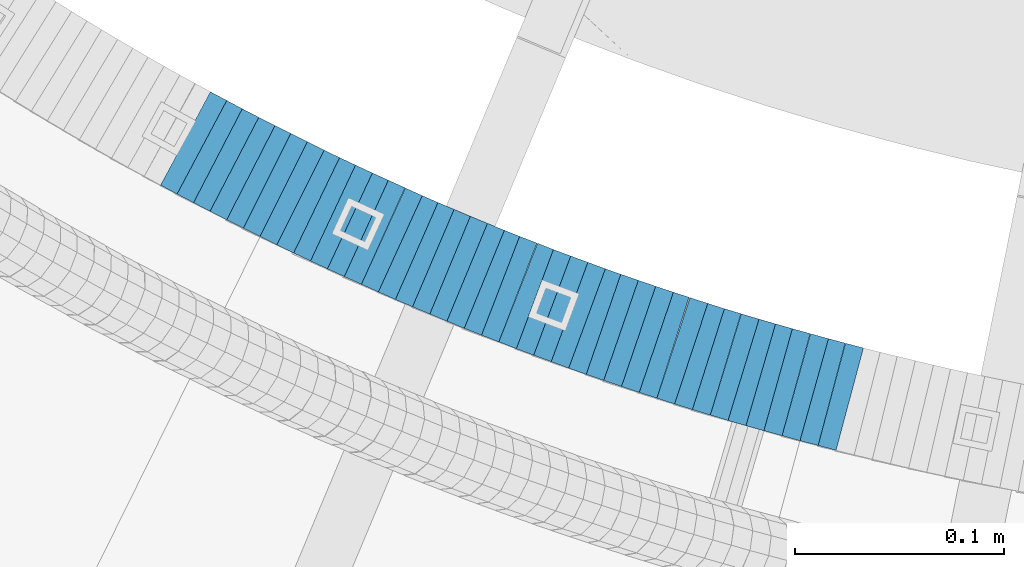
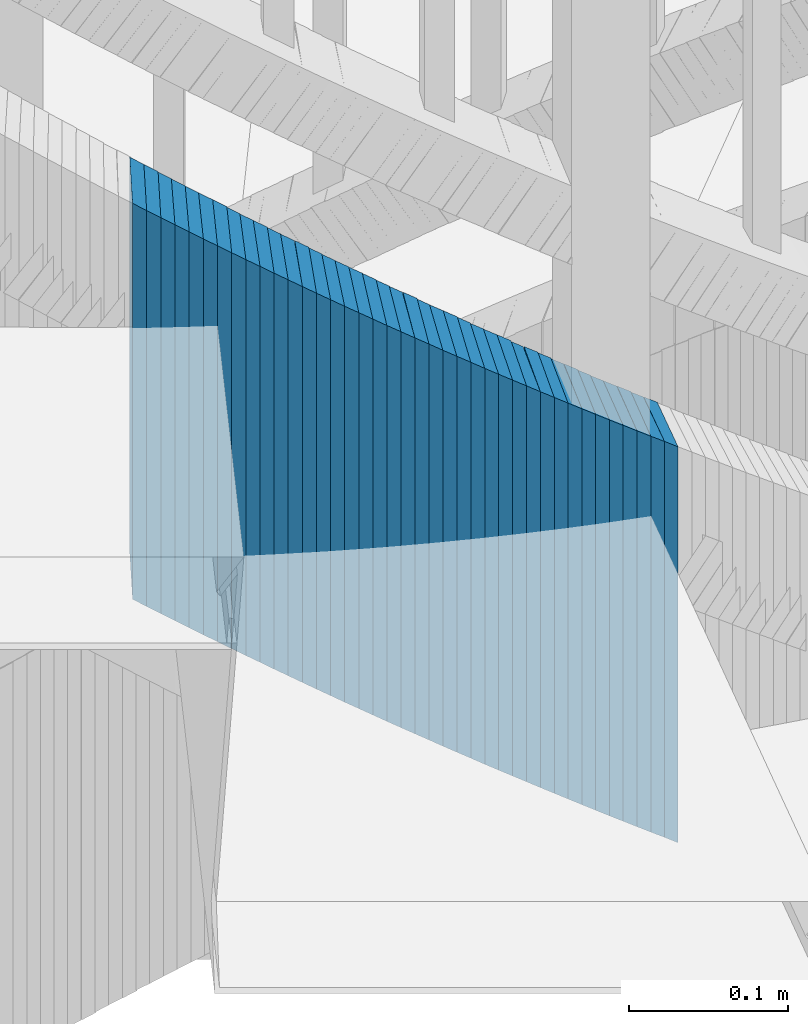
# One storey, part 879 of 975: 39 plates.
"""IFC2X3 building model written with IfcOpenShell, lengths in millimetres."""

from ifc_helpers import new_model, si_unit, frame, origin_with_axes, place, context, subcontext, project, spatial, faceted_brep, material, type_object, element, save


model = new_model("IFC2X3")

# Units and contexts
model_context = context("Model", 3, precision=1e-05, world=origin_with_axes())
body_context = subcontext(model_context, "Body", "Model", "MODEL_VIEW")
ifc_project = project(units=[si_unit("LENGTHUNIT", "METRE", prefix="MILLI"), si_unit("AREAUNIT", "SQUARE_METRE"), si_unit("VOLUMEUNIT", "CUBIC_METRE"), si_unit("MASSUNIT", "GRAM", prefix="KILO"), si_unit("TIMEUNIT", "SECOND"), si_unit("PLANEANGLEUNIT", "RADIAN"), si_unit("SOLIDANGLEUNIT", "STERADIAN"), si_unit("THERMODYNAMICTEMPERATUREUNIT", "DEGREE_CELSIUS"), si_unit("LUMINOUSINTENSITYUNIT", "LUMEN")], contexts=[model_context])

# Site, building, storey
site_placement = place(None, origin_with_axes())
site = spatial("IfcSite", under=ifc_project, at=site_placement, CompositionType="ELEMENT")
building_placement = place(site_placement, origin_with_axes())
building = spatial("IfcBuilding", under=site, at=building_placement, Name="Undefined", CompositionType="ELEMENT")
storey_placement = place(building_placement, origin_with_axes())
storey = spatial("IfcBuildingStorey", under=building, at=storey_placement, Name="Undefined", CompositionType="ELEMENT", Elevation=0.0)

# Plates
ifc_material = material(Name="STEEL/A36")
plate_type = type_object("IfcPlateType", PredefinedType="NOTDEFINED")
plate_1_placement = place(storey_placement, frame((34076.3886920628, 2171.20139217129, 3518.02500005032), z_axis=(-0.882970965859413, 0.469427601925255, 0.0), x_axis=(0.0, 0.0, 1.0)))
element("IfcPlate", 1, at=plate_1_placement, inside=storey, type_object=plate_type, material=ifc_material, Name="WALL", context=body_context, shape_type="Brep", body=[
    faceted_brep([(0.0, -25.3999999999724, -1.81898940354586e-11), (5.80000019073486, -25.3999999999942, 8.94930171964734), (5.80000019073486, 25.4000000000015, 8.94930171966917), (0.0, 25.3999999999869, 1.45519152283669e-11), (310.600006103516, -25.3999999999942, 8.94930171964734), (310.600006103516, 25.4000000000015, 8.94930171966917), (304.799987792969, -25.3999999999724, -1.81898940354586e-11), (304.799987792969, 25.3999999999869, 1.45519152283669e-11)], [[[0, 1, 2, 3]], [[1, 4, 5, 2]], [[4, 6, 7, 5]], [[6, 0, 3, 7]], [[5, 7, 3, 2]], [[6, 4, 1, 0]]]),
])
plate_2_placement = place(storey_placement, frame((34084.288692054, 2167.00139217108, 3512.32500005032), z_axis=(-0.882970965859413, 0.469427601925255, 0.0), x_axis=(0.0, 0.0, 1.0)))
element("IfcPlate", 2, at=plate_2_placement, inside=storey, type_object=plate_type, material=ifc_material, Name="WALL", context=body_context, shape_type="Brep", body=[
    faceted_brep([(0.0, -25.3999999999724, -1.81898940354586e-11), (5.69999980926514, -25.3999999999869, 8.94930171964734), (5.69999980926514, 25.4000000000051, 8.94930171966917), (0.0, 25.3999999999869, 1.45519152283669e-11), (310.5, -25.3999999999869, 8.94930171964734), (310.5, 25.4000000000051, 8.94930171966917), (304.799987792969, -25.3999999999724, -1.81898940354586e-11), (304.799987792969, 25.3999999999869, 1.45519152283669e-11)], [[[0, 1, 2, 3]], [[1, 4, 5, 2]], [[4, 6, 7, 5]], [[6, 0, 3, 7]], [[5, 7, 3, 2]], [[6, 4, 1, 0]]]),
])
plate_3_placement = place(storey_placement, frame((34091.9656160129, 2163.01857400308, 3506.52500005032), z_axis=(-0.887584423832732, 0.460645080913188, 0.0), x_axis=(0.0, 0.0, 1.0)))
element("IfcPlate", 3, at=plate_3_placement, inside=storey, type_object=plate_type, material=ifc_material, Name="WALL", context=body_context, shape_type="Brep", body=[
    faceted_brep([(0.0, -25.3999999999724, -1.81898940354586e-11), (5.80000019073486, -25.3999999999687, 8.90449333185097), (5.80000019073486, 25.3999999999833, 8.90449333192373), (0.0, 25.3999999999869, 1.45519152283669e-11), (310.600006103516, -25.3999999999687, 8.90449333185097), (310.600006103516, 25.3999999999833, 8.90449333192373), (304.799987792969, -25.3999999999724, -1.81898940354586e-11), (304.799987792969, 25.3999999999869, 1.45519152283669e-11)], [[[0, 1, 2, 3]], [[1, 4, 5, 2]], [[4, 6, 7, 5]], [[6, 0, 3, 7]], [[5, 7, 3, 2]], [[6, 4, 1, 0]]]),
])
plate_4_placement = place(storey_placement, frame((34099.8499370481, 2158.97823420287, 3500.82500005032), z_axis=(-0.889933250612687, 0.4560907908015, 0.0), x_axis=(0.0, 0.0, 1.0)))
element("IfcPlate", 4, at=plate_4_placement, inside=storey, type_object=plate_type, material=ifc_material, Name="WALL", context=body_context, shape_type="Brep", body=[
    faceted_brep([(0.0, -25.3999999999724, -1.81898940354586e-11), (5.69999980926514, -25.4000000000196, 8.98721313477654), (5.69999980926514, 25.4000000000669, 8.98721313470742), (0.0, 25.3999999999869, 1.45519152283669e-11), (310.5, -25.4000000000196, 8.98721313477654), (310.5, 25.4000000000669, 8.98721313470742), (304.799987792969, -25.3999999999724, -1.81898940354586e-11), (304.799987792969, 25.3999999999869, 1.45519152283669e-11)], [[[0, 1, 2, 3]], [[1, 4, 5, 2]], [[4, 6, 7, 5]], [[6, 0, 3, 7]], [[5, 7, 3, 2]], [[6, 4, 1, 0]]]),
])
plate_5_placement = place(storey_placement, frame((34107.6244562762, 2155.09238029339, 3495.02500005032), z_axis=(-0.894427191199916, 0.447213595099958, 0.0), x_axis=(0.0, 0.0, 1.0)))
element("IfcPlate", 5, at=plate_5_placement, inside=storey, type_object=plate_type, material=ifc_material, Name="WALL", context=body_context, shape_type="Brep", body=[
    faceted_brep([(0.0, -25.3999999999724, -1.81898940354586e-11), (5.80000019073486, -25.4000000000087, 8.9375610351708), (5.80000019073486, 25.400000000016, 8.93756103512715), (0.0, 25.3999999999869, 1.45519152283669e-11), (310.600006103516, -25.4000000000087, 8.9375610351708), (310.600006103516, 25.400000000016, 8.93756103512715), (304.799987792969, -25.3999999999724, -1.81898940354586e-11), (304.799987792969, 25.3999999999869, 1.45519152283669e-11)], [[[0, 1, 2, 3]], [[1, 4, 5, 2]], [[4, 6, 7, 5]], [[6, 0, 3, 7]], [[5, 7, 3, 2]], [[6, 4, 1, 0]]]),
])
for number, where, z_axis, x_axis, name in (
    (6, (34115.624456275, 2151.09238029301, 3489.32500005032), (-0.894427191199916, 0.447213595099958, 0.0), (0.0, 0.0, 1.0), "WALL"),
    (7, (34123.6244562739, 2147.09238029269, 3483.62500005032), (-0.894427191199916, 0.447213595099958, 0.0), (0.0, 0.0, 1.0), "WALL"),
):
    element("IfcPlate", number, at=place(storey_placement, frame(where, z_axis=z_axis, x_axis=x_axis)), inside=storey, type_object=plate_type, material=ifc_material, Name=name, context=body_context, shape_type="Brep", body=[
        faceted_brep([(0.0, -25.3999999999724, -1.81898940354586e-11), (5.69999980926514, -25.4000000000851, 8.94035816198448), (5.69999980926514, 25.4000000000524, 8.94035816188989), (0.0, 25.3999999999869, 1.45519152283669e-11), (310.5, -25.4000000000851, 8.94035816198448), (310.5, 25.4000000000524, 8.94035816188989), (304.799987792969, -25.3999999999724, -1.81898940354586e-11), (304.799987792969, 25.3999999999869, 1.45519152283669e-11)], [[[0, 1, 2, 3]], [[1, 4, 5, 2]], [[4, 6, 7, 5]], [[6, 0, 3, 7]], [[5, 7, 3, 2]], [[6, 4, 1, 0]]]),
    ])
plate_6_placement = place(storey_placement, frame((34131.3841476791, 2143.35937204668, 3477.82500005032), z_axis=(-0.901001669715669, 0.433815618863102, 0.0), x_axis=(0.0, 0.0, 1.0)))
element("IfcPlate", 8, at=plate_6_placement, inside=storey, type_object=plate_type, material=ifc_material, Name="WALL", context=body_context, shape_type="Brep", body=[
    faceted_brep([(0.0, -25.3999999999724, -1.81898940354586e-11), (5.80000019073486, -25.4000000000815, 8.99388694768095), (5.80000019073486, 25.4000000000342, 8.99388694761365), (0.0, 25.3999999999869, 1.45519152283669e-11), (310.600006103516, -25.4000000000815, 8.99388694768095), (310.600006103516, 25.4000000000342, 8.99388694761365), (304.799987792969, -25.3999999999724, -1.81898940354586e-11), (304.799987792969, 25.3999999999869, 1.45519152283669e-11)], [[[0, 1, 2, 3]], [[1, 4, 5, 2]], [[4, 6, 7, 5]], [[6, 0, 3, 7]], [[5, 7, 3, 2]], [[6, 4, 1, 0]]]),
])
plate_7_placement = place(storey_placement, frame((34139.2531243221, 2139.66917603114, 3472.12500005032), z_axis=(-0.905324661250481, 0.42472021111751, 0.0), x_axis=(0.0, 0.0, 1.0)))
element("IfcPlate", 9, at=plate_7_placement, inside=storey, type_object=plate_type, material=ifc_material, Name="WALL", context=body_context, shape_type="Brep", body=[
    faceted_brep([(0.0, -25.3999999999724, -1.81898940354586e-11), (5.69999980926514, -25.3999999999869, 8.94930171964734), (5.69999980926514, 25.4000000000051, 8.94930171966917), (0.0, 25.3999999999869, 1.45519152283669e-11), (310.5, -25.3999999999869, 8.94930171964734), (310.5, 25.4000000000051, 8.94930171966917), (304.799987792969, -25.3999999999724, -1.81898940354586e-11), (304.799987792969, 25.3999999999869, 1.45519152283669e-11)], [[[0, 1, 2, 3]], [[1, 4, 5, 2]], [[4, 6, 7, 5]], [[6, 0, 3, 7]], [[5, 7, 3, 2]], [[6, 4, 1, 0]]]),
])
plate_8_placement = place(storey_placement, frame((34147.3531243219, 2135.86917603154, 3466.32500005032), z_axis=(-0.905324661250481, 0.42472021111751, 0.0), x_axis=(0.0, 0.0, 1.0)))
element("IfcPlate", 10, at=plate_8_placement, inside=storey, type_object=plate_type, material=ifc_material, Name="WALL", context=body_context, shape_type="Brep", body=[
    faceted_brep([(0.0, -25.3999999999724, -1.81898940354586e-11), (5.80000019073486, -25.3999999999942, 8.94930171964734), (5.80000019073486, 25.4000000000015, 8.94930171966917), (0.0, 25.3999999999869, 1.45519152283669e-11), (310.600006103516, -25.3999999999942, 8.94930171964734), (310.600006103516, 25.4000000000015, 8.94930171966917), (304.799987792969, -25.3999999999724, -1.81898940354586e-11), (304.799987792969, 25.3999999999869, 1.45519152283669e-11)], [[[0, 1, 2, 3]], [[1, 4, 5, 2]], [[4, 6, 7, 5]], [[6, 0, 3, 7]], [[5, 7, 3, 2]], [[6, 4, 1, 0]]]),
])
plate_9_placement = place(storey_placement, frame((34155.2187876517, 2132.27766182791, 3460.62500005032), z_axis=(-0.909595755607489, 0.415494357820705, 0.0), x_axis=(0.0, 0.0, 1.0)))
element("IfcPlate", 11, at=plate_9_placement, inside=storey, type_object=plate_type, material=ifc_material, Name="WALL", context=body_context, shape_type="Brep", body=[
    faceted_brep([(0.0, -25.3999999999724, -1.81898940354586e-11), (5.69999980926514, -25.4000000000269, 8.91066741947361), (5.69999980926514, 25.4000000000269, 8.91066741941904), (0.0, 25.3999999999869, 1.45519152283669e-11), (310.5, -25.4000000000269, 8.91066741947361), (310.5, 25.4000000000269, 8.91066741941904), (304.799987792969, -25.3999999999724, -1.81898940354586e-11), (304.799987792969, 25.3999999999869, 1.45519152283669e-11)], [[[0, 1, 2, 3]], [[1, 4, 5, 2]], [[4, 6, 7, 5]], [[6, 0, 3, 7]], [[5, 7, 3, 2]], [[6, 4, 1, 0]]]),
])
plate_10_placement = place(storey_placement, frame((34163.3119681854, 2128.62615806683, 3454.82500005032), z_axis=(-0.911505056350151, 0.411288867157996, 0.0), x_axis=(0.0, 0.0, 1.0)))
element("IfcPlate", 12, at=plate_10_placement, inside=storey, type_object=plate_type, material=ifc_material, Name="WALL", context=body_context, shape_type="Brep", body=[
    faceted_brep([(0.0, -25.3999999999724, -1.81898940354586e-11), (5.80000019073486, -25.3999999999978, 9.00055599211555), (5.80000019073486, 25.3999999999651, 9.00055599218103), (0.0, 25.3999999999869, 1.45519152283669e-11), (310.600006103516, -25.3999999999978, 9.00055599211555), (310.600006103516, 25.3999999999651, 9.00055599218103), (304.799987792969, -25.3999999999724, -1.81898940354586e-11), (304.799987792969, 25.3999999999869, 1.45519152283669e-11)], [[[0, 1, 2, 3]], [[1, 4, 5, 2]], [[4, 6, 7, 5]], [[6, 0, 3, 7]], [[5, 7, 3, 2]], [[6, 4, 1, 0]]]),
])
plate_11_placement = place(storey_placement, frame((34171.5187876517, 2124.87766182869, 3449.12500005032), z_axis=(-0.909595755607489, 0.415494357820705, 0.0), x_axis=(0.0, 0.0, 1.0)))
element("IfcPlate", 13, at=plate_11_placement, inside=storey, type_object=plate_type, material=ifc_material, Name="WALL", context=body_context, shape_type="Brep", body=[
    faceted_brep([(0.0, -25.3999999999724, -1.81898940354586e-11), (5.69999980926514, -25.4000000000269, 8.91066741947361), (5.69999980926514, 25.4000000000269, 8.91066741941904), (0.0, 25.3999999999869, 1.45519152283669e-11), (310.5, -25.4000000000269, 8.91066741947361), (310.5, 25.4000000000269, 8.91066741941904), (304.799987792969, -25.3999999999724, -1.81898940354586e-11), (304.799987792969, 25.3999999999869, 1.45519152283669e-11)], [[[0, 1, 2, 3]], [[1, 4, 5, 2]], [[4, 6, 7, 5]], [[6, 0, 3, 7]], [[5, 7, 3, 2]], [[6, 4, 1, 0]]]),
])
plate_12_placement = place(storey_placement, frame((34179.3757785416, 2121.43128800254, 3443.42500005032), z_axis=(-0.91564403017333, 0.401990062076095, 0.0), x_axis=(0.0, 0.0, 1.0)))
element("IfcPlate", 14, at=plate_12_placement, inside=storey, type_object=plate_type, material=ifc_material, Name="WALL", context=body_context, shape_type="Brep", body=[
    faceted_brep([(0.0, -25.3999999999724, -1.81898940354586e-11), (5.69999980926514, -25.3999999999105, 8.96270084374919), (5.69999980926514, 25.399999999936, 8.96270084385469), (0.0, 25.3999999999869, 1.45519152283669e-11), (310.5, -25.3999999999105, 8.96270084374919), (310.5, 25.399999999936, 8.96270084385469), (304.799987792969, -25.3999999999724, -1.81898940354586e-11), (304.799987792969, 25.3999999999869, 1.45519152283669e-11)], [[[0, 1, 2, 3]], [[1, 4, 5, 2]], [[4, 6, 7, 5]], [[6, 0, 3, 7]], [[5, 7, 3, 2]], [[6, 4, 1, 0]]]),
])
plate_13_placement = place(storey_placement, frame((34187.3363870016, 2118.03492378168, 3437.62500005032), z_axis=(-0.919724178945735, 0.392565197976837, 0.0), x_axis=(0.0, 0.0, 1.0)))
element("IfcPlate", 15, at=plate_13_placement, inside=storey, type_object=plate_type, material=ifc_material, Name="WALL", context=body_context, shape_type="Brep", body=[
    faceted_brep([(0.0, -25.3999999999724, -1.81898940354586e-11), (5.80000019073486, -25.3999999999633, 8.91964149466003), (5.80000019073486, 25.3999999999669, 8.91964149481646), (0.0, 25.3999999999869, 1.45519152283669e-11), (310.600006103516, -25.3999999999633, 8.91964149466003), (310.600006103516, 25.3999999999669, 8.91964149481646), (304.799987792969, -25.3999999999724, -1.81898940354586e-11), (304.799987792969, 25.3999999999869, 1.45519152283669e-11)], [[[0, 1, 2, 3]], [[1, 4, 5, 2]], [[4, 6, 7, 5]], [[6, 0, 3, 7]], [[5, 7, 3, 2]], [[6, 4, 1, 0]]]),
])
plate_14_placement = place(storey_placement, frame((34195.5344834481, 2114.57815693966, 3431.92500005032), z_axis=(-0.921426271776065, 0.388553246905571, 0.0), x_axis=(0.0, 0.0, 1.0)))
element("IfcPlate", 16, at=plate_14_placement, inside=storey, type_object=plate_type, material=ifc_material, Name="WALL", context=body_context, shape_type="Brep", body=[
    faceted_brep([(0.0, -25.3999999999724, -1.81898940354586e-11), (5.69999980926514, -25.4000000000233, 9.01387786867781), (5.69999980926514, 25.400000000016, 9.01387786863415), (0.0, 25.3999999999869, 1.45519152283669e-11), (310.5, -25.4000000000233, 9.01387786867781), (310.5, 25.400000000016, 9.01387786863415), (304.799987792969, -25.3999999999724, -1.81898940354586e-11), (304.799987792969, 25.3999999999869, 1.45519152283669e-11)], [[[0, 1, 2, 3]], [[1, 4, 5, 2]], [[4, 6, 7, 5]], [[6, 0, 3, 7]], [[5, 7, 3, 2]], [[6, 4, 1, 0]]]),
])
plate_15_placement = place(storey_placement, frame((34203.5938125536, 2111.23697932037, 3426.22500005032), z_axis=(-0.923742113528485, 0.383015022804495, 0.0), x_axis=(0.0, 0.0, 1.0)))
element("IfcPlate", 17, at=plate_15_placement, inside=storey, type_object=plate_type, material=ifc_material, Name="WALL", context=body_context, shape_type="Brep", body=[
    faceted_brep([(0.0, -25.3999999999724, -1.81898940354586e-11), (5.69999980926514, -25.4000000000306, 8.88144111634756), (5.69999980926514, 25.4000000000378, 8.88144111629663), (0.0, 25.3999999999869, 1.45519152283669e-11), (310.5, -25.4000000000306, 8.88144111634756), (310.5, 25.4000000000378, 8.88144111629663), (304.799987792969, -25.3999999999724, -1.81898940354586e-11), (304.799987792969, 25.3999999999869, 1.45519152283669e-11)], [[[0, 1, 2, 3]], [[1, 4, 5, 2]], [[4, 6, 7, 5]], [[6, 0, 3, 7]], [[5, 7, 3, 2]], [[6, 4, 1, 0]]]),
])
plate_16_placement = place(storey_placement, frame((34211.7935308769, 2107.87830882516, 3420.42500005032), z_axis=(-0.925369259401997, 0.379066925164674, 0.0), x_axis=(0.0, 0.0, 1.0)))
element("IfcPlate", 18, at=plate_16_placement, inside=storey, type_object=plate_type, material=ifc_material, Name="WALL", context=body_context, shape_type="Brep", body=[
    faceted_brep([(0.0, -25.3999999999724, -1.81898940354586e-11), (5.80000019073486, -25.4000000000087, 8.96939277650381), (5.80000019073486, 25.3999999999905, 8.969392776522), (0.0, 25.3999999999869, 1.45519152283669e-11), (310.600006103516, -25.4000000000087, 8.96939277650381), (310.600006103516, 25.3999999999905, 8.969392776522), (304.799987792969, -25.3999999999724, -1.81898940354586e-11), (304.799987792969, 25.3999999999869, 1.45519152283669e-11)], [[[0, 1, 2, 3]], [[1, 4, 5, 2]], [[4, 6, 7, 5]], [[6, 0, 3, 7]], [[5, 7, 3, 2]], [[6, 4, 1, 0]]]),
])
plate_17_placement = place(storey_placement, frame((34219.849504121, 2104.67679847575, 3414.72500005032), z_axis=(-0.929246804682174, 0.369459572873636, 0.0), x_axis=(0.0, 0.0, 1.0)))
element("IfcPlate", 19, at=plate_17_placement, inside=storey, type_object=plate_type, material=ifc_material, Name="WALL", context=body_context, shape_type="Brep", body=[
    faceted_brep([(0.0, -25.3999999999724, -1.81898940354586e-11), (5.69999980926514, -25.3999999999542, 8.93084526058738), (5.69999980926514, 25.3999999999178, 8.93084526067832), (0.0, 25.3999999999869, 1.45519152283669e-11), (310.5, -25.3999999999542, 8.93084526058738), (310.5, 25.3999999999178, 8.93084526067832), (304.799987792969, -25.3999999999724, -1.81898940354586e-11), (304.799987792969, 25.3999999999869, 1.45519152283669e-11)], [[[0, 1, 2, 3]], [[1, 4, 5, 2]], [[4, 6, 7, 5]], [[6, 0, 3, 7]], [[5, 7, 3, 2]], [[6, 4, 1, 0]]]),
])
plate_18_placement = place(storey_placement, frame((34227.902430581, 2101.57354109534, 3409.02500005032), z_axis=(-0.933055569241503, 0.359732268093112, 0.0), x_axis=(0.0, 0.0, 1.0)))
element("IfcPlate", 20, at=plate_18_placement, inside=storey, type_object=plate_type, material=ifc_material, Name="WALL", context=body_context, shape_type="Brep", body=[
    faceted_brep([(0.0, -25.3999999999724, -1.81898940354586e-11), (5.69999980926514, -25.3999999999469, 8.90224647518698), (5.69999980926514, 25.399999999936, 8.90224647526338), (0.0, 25.3999999999869, 1.45519152283669e-11), (310.5, -25.3999999999469, 8.90224647518698), (310.5, 25.399999999936, 8.90224647526338), (304.799987792969, -25.3999999999724, -1.81898940354586e-11), (304.799987792969, 25.3999999999869, 1.45519152283669e-11)], [[[0, 1, 2, 3]], [[1, 4, 5, 2]], [[4, 6, 7, 5]], [[6, 0, 3, 7]], [[5, 7, 3, 2]], [[6, 4, 1, 0]]]),
])
plate_19_placement = place(storey_placement, frame((34236.4528012223, 2098.21501757216, 3403.32500005032), z_axis=(-0.930751493659131, 0.365652371866088, 0.0), x_axis=(0.0, 0.0, 1.0)))
element("IfcPlate", 21, at=plate_19_placement, inside=storey, type_object=plate_type, material=ifc_material, Name="WALL", context=body_context, shape_type="Brep", body=[
    faceted_brep([(0.0, -25.3999999999724, -1.81898940354586e-11), (5.69999980926514, -25.4000000000087, 9.02108669283189), (5.69999980926514, 25.4000000000087, 9.02108669277368), (0.0, 25.3999999999869, 1.45519152283669e-11), (310.5, -25.4000000000087, 9.02108669283189), (310.5, 25.4000000000087, 9.02108669277368), (304.799987792969, -25.3999999999724, -1.81898940354586e-11), (304.799987792969, 25.3999999999869, 1.45519152283669e-11)], [[[0, 1, 2, 3]], [[1, 4, 5, 2]], [[4, 6, 7, 5]], [[6, 0, 3, 7]], [[5, 7, 3, 2]], [[6, 4, 1, 0]]]),
])
plate_20_placement = place(storey_placement, frame((34244.3523415094, 2095.2684514056, 3397.52500005032), z_axis=(-0.936792195612456, 0.349886241855254, 0.0), x_axis=(0.0, 0.0, 1.0)))
element("IfcPlate", 22, at=plate_20_placement, inside=storey, type_object=plate_type, material=ifc_material, Name="WALL", context=body_context, shape_type="Brep", body=[
    faceted_brep([(0.0, -25.3999999999724, -1.81898940354586e-11), (5.80000019073486, -25.4000000000106, 8.86171531681612), (5.80000019073486, 25.4000000000015, 8.86171531675791), (0.0, 25.3999999999869, 1.45519152283669e-11), (310.600006103516, -25.4000000000106, 8.86171531681612), (310.600006103516, 25.4000000000015, 8.86171531675791), (304.799987792969, -25.3999999999724, -1.81898940354586e-11), (304.799987792969, 25.3999999999869, 1.45519152283669e-11)], [[[0, 1, 2, 3]], [[1, 4, 5, 2]], [[4, 6, 7, 5]], [[6, 0, 3, 7]], [[5, 7, 3, 2]], [[6, 4, 1, 0]]]),
])
for number, where, z_axis, x_axis, name in (
    (23, (34252.6592918592, 2092.20299787228, 3391.82500005032), (-0.938152292731597, 0.346222869900947, 0.0), (0.0, 0.0, 1.0), "WALL"),
    (24, (34261.0592918567, 2089.10299787186, 3386.12500005032), (-0.938152292731597, 0.346222869900947, 0.0), (0.0, 0.0, 1.0), "WALL"),
):
    element("IfcPlate", number, at=place(storey_placement, frame(where, z_axis=z_axis, x_axis=x_axis)), inside=storey, type_object=plate_type, material=ifc_material, Name=name, context=body_context, shape_type="Brep", body=[
        faceted_brep([(0.0, -25.3999999999724, -1.81898940354586e-11), (5.69999980926514, -25.3999999999869, 8.94930171964734), (5.69999980926514, 25.4000000000051, 8.94930171966917), (0.0, 25.3999999999869, 1.45519152283669e-11), (310.5, -25.3999999999869, 8.94930171964734), (310.5, 25.4000000000051, 8.94930171966917), (304.799987792969, -25.3999999999724, -1.81898940354586e-11), (304.799987792969, 25.3999999999869, 1.45519152283669e-11)], [[[0, 1, 2, 3]], [[1, 4, 5, 2]], [[4, 6, 7, 5]], [[6, 0, 3, 7]], [[5, 7, 3, 2]], [[6, 4, 1, 0]]]),
    ])
plate_21_placement = place(storey_placement, frame((34269.2081754384, 2086.19417419218, 3380.32500005032), z_axis=(-0.941741911640086, 0.33633639687146, 0.0), x_axis=(0.0, 0.0, 1.0)))
element("IfcPlate", 25, at=plate_21_placement, inside=storey, type_object=plate_type, material=ifc_material, Name="WALL", context=body_context, shape_type="Brep", body=[
    faceted_brep([(0.0, -25.3999999999724, -1.81898940354586e-11), (5.80000019073486, -25.3999999999633, 8.91964149466003), (5.80000019073486, 25.3999999999669, 8.91964149481646), (0.0, 25.3999999999869, 1.45519152283669e-11), (310.600006103516, -25.3999999999633, 8.91964149466003), (310.600006103516, 25.3999999999669, 8.91964149481646), (304.799987792969, -25.3999999999724, -1.81898940354586e-11), (304.799987792969, 25.3999999999869, 1.45519152283669e-11)], [[[0, 1, 2, 3]], [[1, 4, 5, 2]], [[4, 6, 7, 5]], [[6, 0, 3, 7]], [[5, 7, 3, 2]], [[6, 4, 1, 0]]]),
])
plate_22_placement = place(storey_placement, frame((34277.3542024391, 2083.38336427624, 3374.62500005032), z_axis=(-0.945253332256942, 0.326337460088705, 0.0), x_axis=(0.0, 0.0, 1.0)))
element("IfcPlate", 26, at=plate_22_placement, inside=storey, type_object=plate_type, material=ifc_material, Name="WALL", context=body_context, shape_type="Brep", body=[
    faceted_brep([(0.0, -25.3999999999724, -1.81898940354586e-11), (5.69999980926514, -25.4000000000196, 8.88650703432359), (5.69999980926514, 25.3999999999614, 8.88650703433086), (0.0, 25.3999999999869, 1.45519152283669e-11), (310.5, -25.4000000000196, 8.88650703432359), (310.5, 25.3999999999614, 8.88650703433086), (304.799987792969, -25.3999999999724, -1.81898940354586e-11), (304.799987792969, 25.3999999999869, 1.45519152283669e-11)], [[[0, 1, 2, 3]], [[1, 4, 5, 2]], [[4, 6, 7, 5]], [[6, 0, 3, 7]], [[5, 7, 3, 2]], [[6, 4, 1, 0]]]),
])
for number, where, z_axis, x_axis, name in (
    (27, (34285.7669068985, 2080.5133246301, 3368.92500005032), (-0.946432873739402, 0.32290062791109, 0.0), (0.0, 0.0, 1.0), "WALL"),
    (28, (34294.2669069063, 2077.61332463035, 3363.22500005032), (-0.946432873739402, 0.32290062791109, 0.0), (0.0, 0.0, 1.0), "WALL"),
):
    element("IfcPlate", number, at=place(storey_placement, frame(where, z_axis=z_axis, x_axis=x_axis)), inside=storey, type_object=plate_type, material=ifc_material, Name=name, context=body_context, shape_type="Brep", body=[
        faceted_brep([(0.0, -25.3999999999724, -1.81898940354586e-11), (5.69999980926514, -25.3999999999542, 8.98276138300935), (5.69999980926514, 25.3999999999614, 8.98276138309302), (0.0, 25.3999999999869, 1.45519152283669e-11), (310.5, -25.3999999999542, 8.98276138300935), (310.5, 25.3999999999614, 8.98276138309302), (304.799987792969, -25.3999999999724, -1.81898940354586e-11), (304.799987792969, 25.3999999999869, 1.45519152283669e-11)], [[[0, 1, 2, 3]], [[1, 4, 5, 2]], [[4, 6, 7, 5]], [[6, 0, 3, 7]], [[5, 7, 3, 2]], [[6, 4, 1, 0]]]),
    ])
plate_23_placement = place(storey_placement, frame((34302.254847586, 2075.08198193654, 3357.42500005032), z_axis=(-0.953072925181811, 0.302740812057751, 0.0), x_axis=(0.0, 0.0, 1.0)))
element("IfcPlate", 29, at=plate_23_placement, inside=storey, type_object=plate_type, material=ifc_material, Name="WALL", context=body_context, shape_type="Brep", body=[
    faceted_brep([(0.0, -25.3999999999724, -1.81898940354586e-11), (5.80000019073486, -25.3999999999633, 8.91964149466003), (5.80000019073486, 25.3999999999669, 8.91964149481646), (0.0, 25.3999999999869, 1.45519152283669e-11), (310.600006103516, -25.3999999999633, 8.91964149466003), (310.600006103516, 25.3999999999669, 8.91964149481646), (304.799987792969, -25.3999999999724, -1.81898940354586e-11), (304.799987792969, 25.3999999999869, 1.45519152283669e-11)], [[[0, 1, 2, 3]], [[1, 4, 5, 2]], [[4, 6, 7, 5]], [[6, 0, 3, 7]], [[5, 7, 3, 2]], [[6, 4, 1, 0]]]),
])
plate_24_placement = place(storey_placement, frame((34311.0122197636, 2072.19871707474, 3351.72500005032), z_axis=(-0.949794781024638, 0.312873575008117, 0.0), x_axis=(0.0, 0.0, 1.0)))
element("IfcPlate", 30, at=plate_24_placement, inside=storey, type_object=plate_type, material=ifc_material, Name="WALL", context=body_context, shape_type="Brep", body=[
    faceted_brep([(0.0, -25.3999999999724, -1.81898940354586e-11), (5.69999980926514, -25.3999999999869, 8.94930171964734), (5.69999980926514, 25.4000000000051, 8.94930171966917), (0.0, 25.3999999999869, 1.45519152283669e-11), (310.5, -25.3999999999869, 8.94930171964734), (310.5, 25.4000000000051, 8.94930171966917), (304.799987792969, -25.3999999999724, -1.81898940354586e-11), (304.799987792969, 25.3999999999869, 1.45519152283669e-11)], [[[0, 1, 2, 3]], [[1, 4, 5, 2]], [[4, 6, 7, 5]], [[6, 0, 3, 7]], [[5, 7, 3, 2]], [[6, 4, 1, 0]]]),
])
plate_25_placement = place(storey_placement, frame((34319.2548475871, 2069.58198193668, 3346.02500005032), z_axis=(-0.953072925181811, 0.302740812057751, 0.0), x_axis=(0.0, 0.0, 1.0)))
element("IfcPlate", 31, at=plate_25_placement, inside=storey, type_object=plate_type, material=ifc_material, Name="WALL", context=body_context, shape_type="Brep", body=[
    faceted_brep([(0.0, -25.3999999999724, -1.81898940354586e-11), (5.69999980926514, -25.4000000000269, 8.9196414947728), (5.69999980926514, 25.3999999999796, 8.91964149476189), (0.0, 25.3999999999869, 1.45519152283669e-11), (310.5, -25.4000000000269, 8.9196414947728), (310.5, 25.3999999999796, 8.91964149476189), (304.799987792969, -25.3999999999724, -1.81898940354586e-11), (304.799987792969, 25.3999999999869, 1.45519152283669e-11)], [[[0, 1, 2, 3]], [[1, 4, 5, 2]], [[4, 6, 7, 5]], [[6, 0, 3, 7]], [[5, 7, 3, 2]], [[6, 4, 1, 0]]]),
])
plate_26_placement = place(storey_placement, frame((34327.5157242879, 2067.08709989178, 3340.22500005032), z_axis=(-0.957211427350145, 0.289389501105858, 0.0), x_axis=(0.0, 0.0, 1.0)))
element("IfcPlate", 32, at=plate_26_placement, inside=storey, type_object=plate_type, material=ifc_material, Name="WALL", context=body_context, shape_type="Brep", body=[
    faceted_brep([(0.0, -25.3999999999724, -1.81898940354586e-11), (5.80000019073486, -25.3999999999432, 8.98109149925949), (5.80000019073486, 25.3999999999651, 8.98109149937954), (0.0, 25.3999999999869, 1.45519152283669e-11), (310.600006103516, -25.3999999999432, 8.98109149925949), (310.600006103516, 25.3999999999651, 8.98109149937954), (304.799987792969, -25.3999999999724, -1.81898940354586e-11), (304.799987792969, 25.3999999999869, 1.45519152283669e-11)], [[[0, 1, 2, 3]], [[1, 4, 5, 2]], [[4, 6, 7, 5]], [[6, 0, 3, 7]], [[5, 7, 3, 2]], [[6, 4, 1, 0]]]),
])
plate_27_placement = place(storey_placement, frame((34336.094841243, 2064.46304018105, 3334.52500005032), z_axis=(-0.956264194770848, 0.29250434150498, 1.32571130961878e-10), x_axis=(0.0, 0.0, 1.0)))
element("IfcPlate", 33, at=plate_27_placement, inside=storey, type_object=plate_type, material=ifc_material, Name="WALL", context=body_context, shape_type="Brep", body=[
    faceted_brep([(0.0, -25.3999999999724, -1.81898940354586e-11), (5.69999980926514, -25.4000000000196, 8.88650703432359), (5.69999980926514, 25.3999999999614, 8.88650703433086), (0.0, 25.3999999999869, 1.45519152283669e-11), (310.5, -25.4000000000196, 8.88650703432359), (310.5, 25.3999999999614, 8.88650703433086), (304.799987792969, -25.3999999999724, -1.81898940354586e-11), (304.799987792969, 25.3999999999869, 1.45519152283669e-11)], [[[0, 1, 2, 3]], [[1, 4, 5, 2]], [[4, 6, 7, 5]], [[6, 0, 3, 7]], [[5, 7, 3, 2]], [[6, 4, 1, 0]]]),
])
plate_28_placement = place(storey_placement, frame((34344.3554469745, 2062.06427274309, 3328.72500005032), z_axis=(-0.96024972858431, 0.279142362879158, 0.0), x_axis=(0.0, 0.0, 1.0)))
element("IfcPlate", 34, at=plate_28_placement, inside=storey, type_object=plate_type, material=ifc_material, Name="WALL", context=body_context, shape_type="Brep", body=[
    faceted_brep([(0.0, -25.3999999999724, -1.81898940354586e-11), (5.80000019073486, -25.3999999999105, 8.96270084375283), (5.80000019073486, 25.399999999936, 8.96270084385833), (0.0, 25.3999999999869, 1.45519152283669e-11), (310.600006103516, -25.3999999999105, 8.96270084375283), (310.600006103516, 25.399999999936, 8.96270084385833), (304.799987792969, -25.3999999999724, -1.81898940354586e-11), (304.799987792969, 25.3999999999869, 1.45519152283669e-11)], [[[0, 1, 2, 3]], [[1, 4, 5, 2]], [[4, 6, 7, 5]], [[6, 0, 3, 7]], [[5, 7, 3, 2]], [[6, 4, 1, 0]]]),
])
plate_29_placement = place(storey_placement, frame((34352.6927247398, 2059.73911568918, 3323.02500005032), z_axis=(-0.963196301261052, 0.268798968072851, 0.0), x_axis=(0.0, 0.0, 1.0)))
element("IfcPlate", 35, at=plate_29_placement, inside=storey, type_object=plate_type, material=ifc_material, Name="WALL", context=body_context, shape_type="Brep", body=[
    faceted_brep([(0.0, -25.3999999999724, -1.81898940354586e-11), (5.69999980926514, -25.3999999999542, 8.93084526058738), (5.69999980926514, 25.3999999999178, 8.93084526067832), (0.0, 25.3999999999869, 1.45519152283669e-11), (310.5, -25.3999999999542, 8.93084526058738), (310.5, 25.3999999999178, 8.93084526067832), (304.799987792969, -25.3999999999724, -1.81898940354586e-11), (304.799987792969, 25.3999999999869, 1.45519152283669e-11)], [[[0, 1, 2, 3]], [[1, 4, 5, 2]], [[4, 6, 7, 5]], [[6, 0, 3, 7]], [[5, 7, 3, 2]], [[6, 4, 1, 0]]]),
])
plate_30_placement = place(storey_placement, frame((34361.3198275072, 2057.35934214027, 3317.22500005032), z_axis=(-0.963992618223753, 0.265928998061726, 0.0), x_axis=(0.0, 0.0, 1.0)))
element("IfcPlate", 36, at=plate_30_placement, inside=storey, type_object=plate_type, material=ifc_material, Name="WALL", context=body_context, shape_type="Brep", body=[
    faceted_brep([(0.0, -25.3999999999724, -1.81898940354586e-11), (5.80000019073486, -25.4000000000997, 9.0210866928719), (5.80000019073486, 25.4000000000451, 9.02108669277732), (0.0, 25.3999999999869, 1.45519152283669e-11), (310.600006103516, -25.4000000000997, 9.0210866928719), (310.600006103516, 25.4000000000451, 9.02108669277732), (304.799987792969, -25.3999999999724, -1.81898940354586e-11), (304.799987792969, 25.3999999999869, 1.45519152283669e-11)], [[[0, 1, 2, 3]], [[1, 4, 5, 2]], [[4, 6, 7, 5]], [[6, 0, 3, 7]], [[5, 7, 3, 2]], [[6, 4, 1, 0]]]),
])
plate_31_placement = place(storey_placement, frame((34369.9927247389, 2054.93911568965, 3311.52500005032), z_axis=(-0.963196301261052, 0.268798968072851, 0.0), x_axis=(0.0, 0.0, 1.0)))
element("IfcPlate", 37, at=plate_31_placement, inside=storey, type_object=plate_type, material=ifc_material, Name="WALL", context=body_context, shape_type="Brep", body=[
    faceted_brep([(0.0, -25.3999999999724, -1.81898940354586e-11), (5.69999980926514, -25.3999999999542, 8.93084526058738), (5.69999980926514, 25.3999999999178, 8.93084526067832), (0.0, 25.3999999999869, 1.45519152283669e-11), (310.5, -25.3999999999542, 8.93084526058738), (310.5, 25.3999999999178, 8.93084526067832), (304.799987792969, -25.3999999999724, -1.81898940354586e-11), (304.799987792969, 25.3999999999869, 1.45519152283669e-11)], [[[0, 1, 2, 3]], [[1, 4, 5, 2]], [[4, 6, 7, 5]], [[6, 0, 3, 7]], [[5, 7, 3, 2]], [[6, 4, 1, 0]]]),
])
plate_32_placement = place(storey_placement, frame((34378.3571435721, 2052.73029481077, 3305.82500005032), z_axis=(-0.966786030429018, 0.255587111113418, 0.0), x_axis=(0.0, 0.0, 1.0)))
element("IfcPlate", 38, at=plate_32_placement, inside=storey, type_object=plate_type, material=ifc_material, Name="WALL", context=body_context, shape_type="Brep", body=[
    faceted_brep([(0.0, -25.3999999999724, -1.81898940354586e-11), (5.69999980926514, -25.3999999999978, 9.00277709959482), (5.69999980926514, 25.3999999999651, 9.00277709966031), (0.0, 25.3999999999869, 1.45519152283669e-11), (310.5, -25.3999999999978, 9.00277709959482), (310.5, 25.3999999999651, 9.00277709966031), (304.799987792969, -25.3999999999724, -1.81898940354586e-11), (304.799987792969, 25.3999999999869, 1.45519152283669e-11)], [[[0, 1, 2, 3]], [[1, 4, 5, 2]], [[4, 6, 7, 5]], [[6, 0, 3, 7]], [[5, 7, 3, 2]], [[6, 4, 1, 0]]]),
])
plate_33_placement = place(storey_placement, frame((34387.027619148, 2050.41155505656, 3300.02500005032), z_axis=(-0.966048244824465, 0.258361739953055, 0.0), x_axis=(0.0, 0.0, 1.0)))
element("IfcPlate", 39, at=plate_33_placement, inside=storey, type_object=plate_type, material=ifc_material, Name="WALL", context=body_context, shape_type="Brep", body=[
    faceted_brep([(0.0, -25.3999999999724, -1.81898940354586e-11), (5.80000019073486, -25.3999999999687, 8.90449333185097), (5.80000019073486, 25.3999999999833, 8.90449333192373), (0.0, 25.3999999999869, 1.45519152283669e-11), (310.600006103516, -25.3999999999687, 8.90449333185097), (310.600006103516, 25.3999999999833, 8.90449333192373), (304.799987792969, -25.3999999999724, -1.81898940354586e-11), (304.799987792969, 25.3999999999869, 1.45519152283669e-11)], [[[0, 1, 2, 3]], [[1, 4, 5, 2]], [[4, 6, 7, 5]], [[6, 0, 3, 7]], [[5, 7, 3, 2]], [[6, 4, 1, 0]]]),
])

save(model, "model.ifc")
